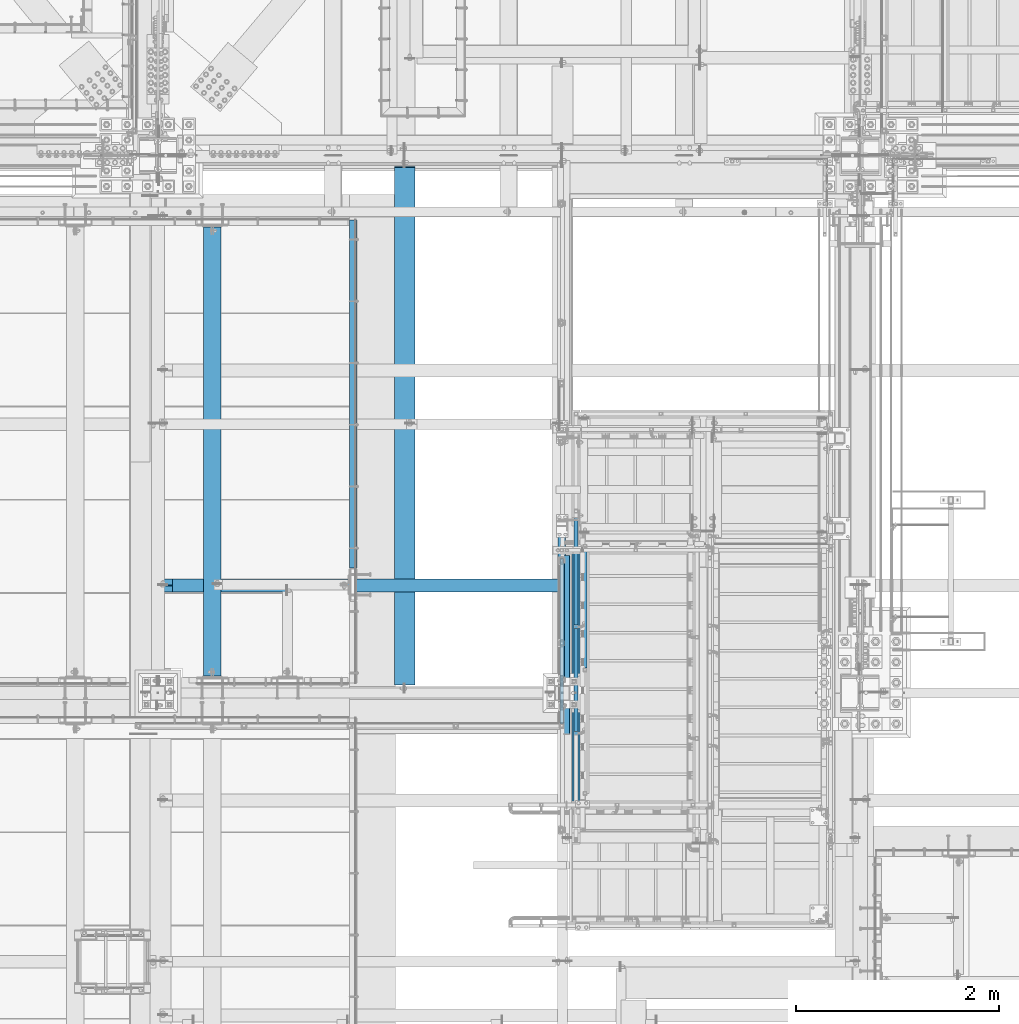
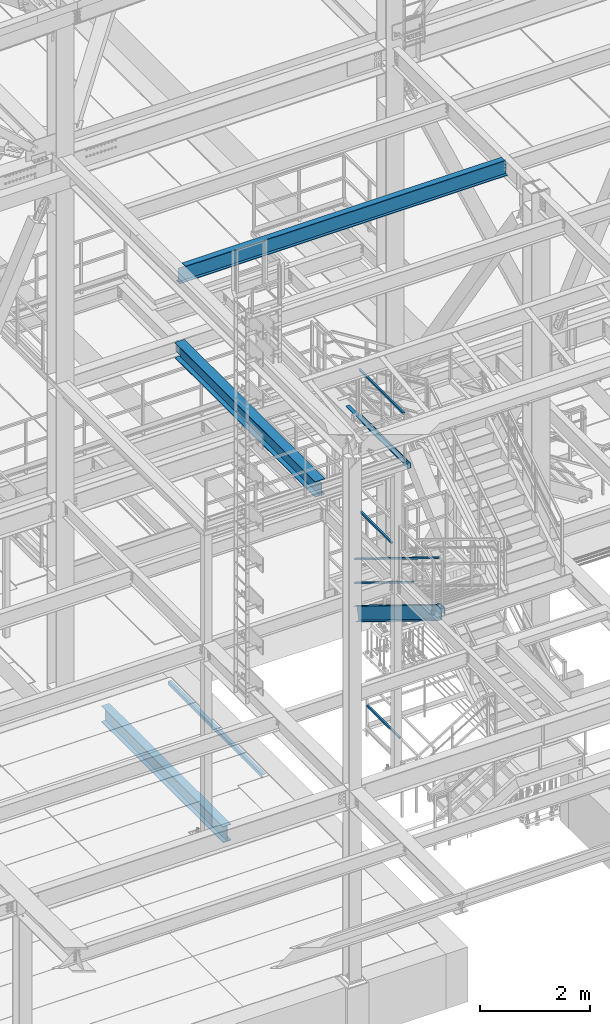
# One storey, part 1758 of 3843: 9 beams, 4 members, 11 elements without a shape of their own.
"""IFC2X3 building model written with IfcOpenShell, lengths in millimetres."""

from ifc_helpers import new_model, si_unit, frame, origin_with_axes, place, context, subcontext, project, spatial, faceted_brep, material, type_object, element, aggregate, save


model = new_model("IFC2X3")

# Units and contexts
model_context = context("Model", 3, precision=1e-05, world=origin_with_axes())
body_context = subcontext(model_context, "Body", "Model", "MODEL_VIEW")
ifc_project = project(units=[si_unit("LENGTHUNIT", "METRE", prefix="MILLI"), si_unit("AREAUNIT", "SQUARE_METRE"), si_unit("VOLUMEUNIT", "CUBIC_METRE"), si_unit("MASSUNIT", "GRAM", prefix="KILO"), si_unit("TIMEUNIT", "SECOND"), si_unit("PLANEANGLEUNIT", "RADIAN"), si_unit("SOLIDANGLEUNIT", "STERADIAN"), si_unit("THERMODYNAMICTEMPERATUREUNIT", "DEGREE_CELSIUS"), si_unit("LUMINOUSINTENSITYUNIT", "LUMEN")], contexts=[model_context])

# Site, building, storey
site_placement = place(None, origin_with_axes())
site = spatial("IfcSite", under=ifc_project, at=site_placement, CompositionType="ELEMENT")
building_placement = place(site_placement, origin_with_axes())
building = spatial("IfcBuilding", under=site, at=building_placement, Name="Undefined", CompositionType="ELEMENT")
storey_placement = place(building_placement, origin_with_axes())
storey = spatial("IfcBuildingStorey", under=building, at=storey_placement, Name="Undefined", CompositionType="ELEMENT", Elevation=0.0)

# Assembly, beam
assembly_1_placement = place(storey_placement, origin_with_axes())
assembly_1 = element("IfcElementAssembly", 1, at=assembly_1_placement, inside=storey, Name="RAIL", AssemblyPlace="NOTDEFINED", PredefinedType="RIGID_FRAME")
ifc_material_1 = material()
beam_type_1 = type_object("IfcBeamType", Name="HSS1-1/2X1-1/2X1/4", PredefinedType="NOTDEFINED")
beam_1_placement = place(assembly_1_placement, frame((52990.75, 21615.3999994262, 35483.7999969486), z_axis=(0.0, 0.0, 1.0), x_axis=(0.0, -1.0, 0.0)))
beam_1 = element("IfcBeam", 2, at=beam_1_placement, type_object=beam_type_1, material=ifc_material_1, Name="RAIL", ObjectType="HSS1-1/2X1-1/2X1/4", context=body_context, shape_type="Brep", body=[
    faceted_brep([(19.0499992350015, -19.0499992350015, -19.0499992350015), (19.0499992350015, -19.0499992350015, 19.0499992350015), (19.0499992350015, 19.0499992350015, 19.0499992350015), (19.0499992350015, 19.0499992350015, -19.0499992350015), (19.0499992350015, 12.6999993299978, 12.6999993299978), (19.0499992350015, -12.6999993299978, 12.6999993299978), (19.0499992350015, -12.6999993299978, -12.6999993299978), (19.0499992350015, 12.6999993299978, -12.6999993299978), (1155.70000095625, 19.0499992350015, -19.0499992350015), (1155.70000095625, -19.0499992350015, -19.0499992350015), (1155.70000095625, -19.0499992350015, 19.0499992350015), (1155.70000095625, 19.0499992350015, 19.0499992350015), (1155.70000095625, -12.6999993299978, 12.6999993299978), (1155.70000095625, 12.6999993299978, 12.6999993299978), (1155.70000095625, 12.6999993299978, -12.6999993299978), (1155.70000095625, -12.6999993299978, -12.6999993299978)], [[[0, 1, 2, 3], [4, 5, 6, 7]], [[8, 9, 0, 3]], [[9, 10, 1, 0]], [[10, 11, 2, 1]], [[11, 8, 3, 2]], [[10, 9, 8, 11], [12, 13, 14, 15]], [[13, 12, 5, 4]], [[14, 13, 4, 7]], [[15, 14, 7, 6]], [[12, 15, 6, 5]]]),
])
aggregate(assembly_1, [beam_1])

assembly_2_placement = place(storey_placement, origin_with_axes())
assembly_2 = element("IfcElementAssembly", 3, at=assembly_2_placement, inside=storey, Name="RAIL", AssemblyPlace="NOTDEFINED", PredefinedType="RIGID_FRAME")
beam_2_placement = place(assembly_2_placement, frame((52984.3999999344, 19964.399988558, 38633.3999983618), z_axis=(0.0, 0.0, -1.0), x_axis=(0.0, 1.0, 0.0)))
beam_2 = element("IfcBeam", 4, at=beam_2_placement, type_object=beam_type_1, material=ifc_material_1, Name="RAIL", ObjectType="HSS1-1/2X1-1/2X1/4", context=body_context, shape_type="Brep", body=[
    faceted_brep([(38.0999984699883, 12.6999993299978, -12.6999993300014), (38.0999984699883, -12.6999993299978, -12.6999993300014), (1663.70001078715, -12.6999993299978, -12.6999993299978), (1663.70001078715, 12.6999993299978, -12.6999993299978), (38.0999984699883, -12.6999993299978, 12.6999993300014), (1638.30001212715, -12.6999993299978, 12.6999993299978), (38.0999984699883, 12.6999993299978, 12.6999993300014), (1638.30001212715, 12.6999993299978, 12.6999993299978), (38.0999984699883, 19.0499992350015, -19.0499992350015), (38.0999984699883, 19.0499992350015, 19.0499992350015), (1631.95001222215, 19.0499992350015, 19.0499992350015), (1670.05001069215, 19.0499992350015, -19.0499992350015), (38.0999984699883, -19.0499992350015, 19.0499992350015), (1631.95001222215, -19.0499992350015, 19.0499992350015), (38.0999984699883, -19.0499992350015, -19.0499992350015), (1670.05001069215, -19.0499992350015, -19.0499992350015)], [[[0, 1, 2, 3]], [[1, 4, 5, 2]], [[4, 6, 7, 5]], [[6, 0, 3, 7]], [[8, 9, 10, 11]], [[9, 12, 13, 10]], [[12, 14, 15, 13]], [[14, 8, 11, 15]], [[13, 15, 11, 10], [5, 7, 3, 2]], [[14, 12, 9, 8], [6, 4, 1, 0]]]),
])
aggregate(assembly_2, [beam_2])

assembly_3_placement = place(storey_placement, origin_with_axes())
assembly_3 = element("IfcElementAssembly", 5, at=assembly_3_placement, inside=storey, Name="RAIL", AssemblyPlace="NOTDEFINED", PredefinedType="RIGID_FRAME")
beam_3_placement = place(assembly_3_placement, frame((53212.999999235, 20535.8999999874, 31013.4), z_axis=(0.0, 0.0, 1.0), x_axis=(0.0, 1.0, 0.0)))
beam_3 = element("IfcBeam", 6, at=beam_3_placement, type_object=beam_type_1, material=ifc_material_1, Name="RAIL", ObjectType="HSS1-1/2X1-1/2X1/4", context=body_context, shape_type="Brep", body=[
    faceted_brep([(1200.15000153688, -19.0499992350015, 19.0499992350015), (1200.15000153688, -19.0499992350015, -19.0499992350015), (1200.15000153688, 19.0499992350015, -19.0499992350015), (1200.15000153688, 19.0499992350015, 19.0499992350015), (1200.15000153688, -12.6999993299978, 12.6999993299978), (1200.15000153688, 12.6999993299978, 12.6999993299978), (1200.15000153688, 12.6999993299978, -12.6999993299978), (1200.15000153688, -12.6999993299978, -12.6999993299978), (19.0499992350015, 19.0499992350015, -19.0499992350015), (19.0499992350015, 19.0499992350015, 19.0499992350015), (19.0499992350015, -19.0499992350015, 19.0499992350015), (19.0499992350015, -19.0499992350015, -19.0499992350015), (19.0499992350015, 12.6999993299978, 12.6999993299978), (19.0499992350015, -12.6999993299978, 12.6999993299978), (19.0499992350015, -12.6999993299978, -12.6999993299978), (19.0499992350015, 12.6999993299978, -12.6999993299978)], [[[0, 1, 2, 3], [4, 5, 6, 7]], [[8, 9, 3, 2]], [[9, 10, 0, 3]], [[10, 11, 1, 0]], [[11, 8, 2, 1]], [[11, 10, 9, 8], [12, 13, 14, 15]], [[14, 13, 4, 7]], [[15, 14, 7, 6]], [[12, 15, 6, 5]], [[13, 12, 5, 4]]]),
])
aggregate(assembly_3, [beam_3])

# Assembly, members
assembly_4_placement = place(storey_placement, origin_with_axes())
assembly_4 = element("IfcElementAssembly", 7, at=assembly_4_placement, inside=storey, Name="RAIL", AssemblyPlace="NOTDEFINED", PredefinedType="RIGID_FRAME")
member_type_1 = type_object("IfcMemberType", Name="HSS1-1/2X1-1/2X1/4", PredefinedType="NOTDEFINED")
member_1_placement = place(assembly_4_placement, frame((53124.100000007, 20961.3499999856, 34252.8769202584), z_axis=(0.0, 0.5240974250506, 0.851658317082227), x_axis=(0.0, -0.851658317082228, 0.524097425050598)))
member_1 = element("IfcMember", 8, at=member_1_placement, type_object=member_type_1, material=ifc_material_1, Name="RAIL", ObjectType="HSS1-1/2X1-1/2X1/4", context=body_context, shape_type="Brep", body=[
    faceted_brep([(14.5527402998268, 12.6999993300014, -12.6999993299833), (14.5527402998268, -12.6999993300014, -12.6999993299833), (1203.79140701925, -12.6999993299978, -12.6999993324425), (1203.79140701925, 12.6999993299978, -12.6999993324425), (30.1835087105574, -12.6999993300014, 12.6999993299978), (1219.42217540003, -12.6999993299978, 12.6999993276258), (30.1835087105574, 12.6999993300014, 12.6999993299978), (1219.42217540003, 12.6999993299978, 12.6999993276258), (10.6450480494532, 19.0499992350015, -19.0499992349796), (34.091200960931, 19.0499992350015, 19.0499992349942), (1223.32986764292, 19.0499992350015, 19.0499992326368), (1199.88371477637, 19.0499992350015, -19.0499992374534), (34.091200960931, -19.0499992350015, 19.0499992349942), (1223.32986764292, -19.0499992350015, 19.0499992326368), (10.6450480494532, -19.0499992350015, -19.0499992349796), (1199.88371477637, -19.0499992350015, -19.0499992374534)], [[[0, 1, 2, 3]], [[1, 4, 5, 2]], [[4, 6, 7, 5]], [[6, 0, 3, 7]], [[8, 9, 10, 11]], [[9, 12, 13, 10]], [[12, 14, 15, 13]], [[14, 8, 11, 15]], [[13, 15, 11, 10], [5, 7, 3, 2]], [[14, 12, 9, 8], [6, 4, 1, 0]]]),
])
member_2_placement = place(assembly_4_placement, frame((53124.1000000089, 22034.5000000458, 33592.4769213096), z_axis=(0.0, 0.5240974250506, 0.851658317082227), x_axis=(0.0, -0.851658317082228, 0.524097425050598)))
member_2 = element("IfcMember", 9, at=member_2_placement, type_object=member_type_1, material=ifc_material_1, Name="RAIL", ObjectType="HSS1-1/2X1-1/2X1/4", context=body_context, shape_type="Brep", body=[
    faceted_brep([(-3.59463567009516, 12.6999993300014, -12.6999993299978), (-3.59463567009516, -12.6999993300014, -12.6999993299978), (1229.88755333165, -12.6999993299978, -12.6999993324789), (1229.88755333165, 12.6999993299978, -12.6999993324789), (3.59463559381402, -12.6999993300014, 12.6999993299833), (1245.51832171243, -12.6999993299978, 12.6999993275822), (3.59463559381402, 12.6999993300014, 12.6999993299833), (1245.51832171243, 12.6999993299978, 12.6999993275822), (-5.39195355401171, 19.0499992350015, -19.0499992349942), (5.39195347770146, 19.0499992350015, 19.0499992349796), (1249.42601395532, 19.0499992350015, 19.0499992325931), (1225.97986108877, 19.0499992350015, -19.0499992374971), (5.39195347770146, -19.0499992350015, 19.0499992349796), (1249.42601395532, -19.0499992350015, 19.0499992325931), (-5.39195355401171, -19.0499992350015, -19.0499992349942), (1225.97986108877, -19.0499992350015, -19.0499992374971)], [[[0, 1, 2, 3]], [[1, 4, 5, 2]], [[4, 6, 7, 5]], [[6, 0, 3, 7]], [[8, 9, 10, 11]], [[9, 12, 13, 10]], [[12, 14, 15, 13]], [[14, 8, 11, 15]], [[13, 15, 11, 10], [5, 7, 3, 2]], [[14, 12, 9, 8], [6, 4, 1, 0]]]),
])
member_3_placement = place(assembly_4_placement, frame((53124.0999999919, 18961.0999971336, 36017.1999969291), z_axis=(0.0, -0.5240974250506, -0.851658317082227), x_axis=(0.0, 0.851658317082228, -0.524097425050598)))
member_3 = element("IfcMember", 10, at=member_3_placement, type_object=member_type_1, material=ifc_material_1, Name="RAIL", ObjectType="HSS1-1/2X1-1/2X1/4", context=body_context, shape_type="Brep", body=[
    faceted_brep([(-3.59463567009516, 12.6999993300014, -12.6999993299978), (-3.59463567009516, -12.6999993300014, -12.6999993299978), (3605.1295924376, -12.6999993299978, -12.6999993372156), (3605.1295924376, 12.6999993299978, -12.6999993372156), (3.59463559381402, -12.6999993300014, 12.6999993299833), (3612.31886368554, -12.6999993299978, 12.6999993228674), (3.59463559381402, 12.6999993300014, 12.6999993299833), (3612.31886368554, 12.6999993299978, 12.6999993228674), (-5.39195355401171, 19.0499992350015, -19.0499992349942), (5.39195347770146, 19.0499992350015, 19.0499992349796), (3614.11618156546, 19.0499992350015, 19.0499992278783), (3603.33227455768, 19.0499992350015, -19.049999242241), (5.39195347770146, -19.0499992350015, 19.0499992349796), (3614.11618156546, -19.0499992350015, 19.0499992278783), (-5.39195355401171, -19.0499992350015, -19.0499992349942), (3603.33227455768, -19.0499992350015, -19.049999242241)], [[[0, 1, 2, 3]], [[1, 4, 5, 2]], [[4, 6, 7, 5]], [[6, 0, 3, 7]], [[8, 9, 10, 11]], [[9, 12, 13, 10]], [[12, 14, 15, 13]], [[14, 8, 11, 15]], [[13, 15, 11, 10], [5, 7, 3, 2]], [[14, 12, 9, 8], [6, 4, 1, 0]]]),
])
aggregate(assembly_4, [member_1, member_2, member_3])

# Assembly, beam
assembly_5_placement = place(storey_placement, origin_with_axes())
assembly_5 = element("IfcElementAssembly", 11, at=assembly_5_placement, inside=storey, Name="ref.", AssemblyPlace="NOTDEFINED", PredefinedType="RIGID_FRAME")
ifc_material_2 = material(Name="STEEL/Steel_Undefined")
beam_type_2 = type_object("IfcBeamType", PredefinedType="NOTDEFINED")
beam_4_placement = place(assembly_5_placement, frame((52984.3999999344, 22066.249987793, 37563.4249983618), z_axis=(1.0, 0.0, 0.0), x_axis=(0.0, -1.0, 0.0)))
beam_4 = element("IfcBeam", 12, at=beam_4_placement, type_object=beam_type_2, material=ifc_material_2, Name="ref.", context=body_context, shape_type="Brep", body=[
    faceted_brep([(0.0, 3.17500000000291, -38.0999999999985), (0.0, 3.17500000000291, 38.0999999999985), (2082.8, 3.17500000000291, 38.0999999999985), (2082.8, 3.17500000000291, -38.0999999999985), (0.0, -3.17500000000291, 38.0999999999985), (2082.8, -3.17500000000291, 38.0999999999985), (0.0, -3.17500000000291, -38.0999999999985), (2082.8, -3.17500000000291, -38.0999999999985)], [[[0, 1, 2, 3]], [[1, 4, 5, 2]], [[4, 6, 7, 5]], [[6, 0, 3, 7]], [[5, 7, 3, 2]], [[6, 4, 1, 0]]]),
])
aggregate(assembly_5, [beam_4])

# Assembly, member
assembly_6_placement = place(storey_placement, origin_with_axes())
assembly_6 = element("IfcElementAssembly", 13, at=assembly_6_placement, inside=storey, Name="STAIR", AssemblyPlace="NOTDEFINED", PredefinedType="RIGID_FRAME")
ifc_material_3 = material(Name="STEEL/A36")
member_type_2 = type_object("IfcMemberType", Name="C12X20.7", PredefinedType="NOTDEFINED")
member_4_placement = place(assembly_6_placement, frame((53124.1000000007, 21961.8168240169, 32954.6841938268), z_axis=(0.0, 0.5240974250506, 0.851658317082227), x_axis=(0.0, -0.851658317082228, 0.524097425050598)))
member_4 = element("IfcMember", 14, at=member_4_placement, type_object=member_type_2, material=ifc_material_3, Name="STAIR", ObjectType="C12X20.7", context=body_context, shape_type="Brep", body=[
    faceted_brep([(3477.78444080407, 30.1624999999985, -134.674927507411), (3470.78595927689, -38.0999999999985, -146.047460007438), (3466.87670389858, -38.0999999999985, -152.400000007459), (3466.87670389858, 38.0999999999985, -152.400000007459), (3558.68671779059, 38.0999999999985, -3.20872719031468), (3558.68671779059, 30.1624999999985, -3.20872719031468), (3645.21520280598, 30.1624999999985, -56.4570255759609), (3645.21520046979, 38.0999999999985, -56.4570241383044), (0.0, -38.0999999999985, 152.400000000001), (-1.79803789807193, -38.1000000000004, 146.047460000002), (3606.93103753184, -38.0999999999985, 146.04745999338), (3596.60816001522, -38.0999999999985, 152.399999993417), (0.0, 38.0999999999985, 152.400000000001), (3596.60816001522, 38.0999999999985, 152.399999993417), (-86.271260601221, -38.1000000000004, -152.400000000001), (-84.4732237670396, -38.1000000000004, -146.047460000002), (-81.2543172614387, 30.1625000000004, -134.6749275), (-5.01694440365827, 30.1625000000004, 134.6749275), (-86.271260601221, 38.1000000000004, -152.400000000001), (3625.41140287409, 30.1624999999985, 134.674927493295), (3725.08764644338, 30.1624999999985, 73.3357007797749), (3725.08764644338, 38.0999999999985, 73.3357007797749)], [[[0, 1, 2, 3, 4, 5]], [[6, 5, 4, 7]], [[8, 9, 10, 11]], [[12, 8, 11, 13]], [[14, 15, 16, 17, 9, 8, 12, 18]], [[9, 17, 19, 10]], [[13, 11, 10, 19, 20, 21]], [[21, 20, 6, 7]], [[3, 18, 12, 13, 21, 7, 4]], [[14, 18, 3, 2]], [[15, 14, 2, 1]], [[16, 15, 1, 0]], [[20, 19, 17, 16, 0, 5, 6]]]),
])
aggregate(assembly_6, [member_4])

# Assembly, beam
assembly_7_placement = place(storey_placement, origin_with_axes())
assembly_7 = element("IfcElementAssembly", 15, at=assembly_7_placement, inside=storey, Name="ANGLE", AssemblyPlace="NOTDEFINED", PredefinedType="RIGID_FRAME")
beam_type_3 = type_object("IfcBeamType", Name="L3X3X1/4", PredefinedType="NOTDEFINED")
beam_5_placement = place(assembly_7_placement, frame((50923.825, 24980.9, 30365.7000030518), z_axis=(0.0, 0.0, -1.0), x_axis=(0.0, -1.0, 0.0)))
beam_5 = element("IfcBeam", 16, at=beam_5_placement, type_object=beam_type_3, material=ifc_material_3, Name="ANGLE", ObjectType="L3X3X1/4", context=body_context, shape_type="Brep", body=[
    faceted_brep([(0.0, 38.0999999999985, -38.0999999999985), (0.0, 38.0999999999985, 38.0999999999985), (3438.525, 38.0999999999985, 38.0999999999985), (3438.525, 38.0999999999985, -38.0999999999985), (0.0, 31.75, 38.0999999999985), (3438.525, 31.75, 38.0999999999985), (0.0, 31.75, -31.75), (3438.525, 31.75, -31.75), (0.0, -38.0999999999985, -31.75), (3438.525, -38.0999999999985, -31.75), (0.0, -38.0999999999985, -38.0999999999985), (3438.525, -38.0999999999985, -38.0999999999985)], [[[0, 1, 2, 3]], [[1, 4, 5, 2]], [[4, 6, 7, 5]], [[6, 8, 9, 7]], [[8, 10, 11, 9]], [[10, 0, 3, 11]], [[5, 7, 9, 11, 3, 2]], [[10, 8, 6, 4, 1, 0]]]),
])
aggregate(assembly_7, [beam_5])

assembly_8_placement = place(storey_placement, origin_with_axes())
assembly_8 = element("IfcElementAssembly", 17, at=assembly_8_placement, inside=storey, Name="BEAM", AssemblyPlace="NOTDEFINED", PredefinedType="RIGID_FRAME")
beam_type_4 = type_object("IfcBeamType", PredefinedType="NOTDEFINED")
beam_6_placement = place(assembly_8_placement, frame((53003.45, 20783.9465, 37468.175), z_axis=(0.0, -1.0, 0.0), x_axis=(1.0, 0.0, 0.0)))
beam_6 = element("IfcBeam", 18, at=beam_6_placement, type_object=beam_type_4, material=ifc_material_3, Name="BENT_PLATE", context=body_context, shape_type="Brep", body=[
    faceted_brep([(0.0, -3.17500000000291, -883.0465), (0.0, -3.17500000000291, 883.0465), (0.0, 3.17500000000291, 883.0465), (0.0, 3.17500000000291, -883.0465), (57.1499999999942, 3.17500000000291, 883.0465), (57.1499999999942, 3.17500000000291, -883.0465), (63.5, -3.17500000000291, -883.0465), (63.5, -3.17500000000291, 883.0465), (57.1499999999942, 98.4249984741182, 883.0465), (57.1499999999942, 98.4249984741182, -883.0465), (63.5, 98.4249984741182, 883.0465), (63.5, 98.4249984741182, -883.0465)], [[[0, 1, 2, 3]], [[3, 2, 4, 5]], [[1, 0, 6, 7]], [[5, 4, 8, 9]], [[4, 2, 1, 7, 10, 8]], [[7, 6, 11, 10]], [[6, 0, 3, 5, 9, 11]], [[10, 11, 9, 8]]]),
])
aggregate(assembly_8, [beam_6])

assembly_9_placement = place(storey_placement, origin_with_axes())
assembly_9 = element("IfcElementAssembly", 19, at=assembly_9_placement, inside=storey, Name="BEAM", AssemblyPlace="NOTDEFINED", PredefinedType="RIGID_FRAME")
ifc_material_4 = material(Name="STEEL/A992")
beam_type_5 = type_object("IfcBeamType", Name="W14X26", PredefinedType="NOTDEFINED")
beam_7_placement = place(assembly_9_placement, frame((48996.6, 21369.02, 42292.5875), z_axis=(0.0, 0.0, 1.0), x_axis=(1.0, 0.0, 0.0)))
beam_7 = element("IfcBeam", 20, at=beam_7_placement, type_object=beam_type_5, material=ifc_material_4, Name="BEAM", ObjectType="W14X26", context=body_context, shape_type="Brep", body=[
    faceted_brep([(6851.64999694825, -63.5, 176.212500000001), (6851.64999694825, -63.5, 165.099999999999), (6851.64999694825, -3.17499999999927, 165.099999999999), (6851.64999694825, -3.17499999999927, 160.33749980927), (6851.64999694825, 3.17499999999927, 160.33749980927), (6851.64999694825, 3.17499999999927, 165.099999999999), (6851.64999694825, 63.5, 165.099999999999), (6851.64999694825, 63.5, 176.212500000001), (6852.61672687083, -3.17499999999927, 155.477420291223), (6852.61672687083, 3.17499999999927, 155.477420291223), (6855.36974077131, -3.17499999999927, 151.357243823069), (6855.36974077131, 3.17499999999927, 151.357243823069), (6859.48991723947, -3.17499999999927, 148.604229922596), (6859.48991723947, 3.17499999999927, 148.604229922596), (6864.34999675751, -3.17499999999927, 147.637500000004), (6864.34999675751, 3.17499999999927, 147.637500000004), (6918.325, -3.17499999999927, 147.637500000004), (6918.325, 3.17499999999927, 147.637500000004), (142.87500610351, -63.5, 176.212500000001), (142.87500610351, 63.5, 176.212500000001), (142.87500610351, 63.5, 165.099999999999), (142.87500610351, 3.17499999999927, 165.099999999999), (142.87500610351, 3.17499999999927, 149.224999809267), (142.87500610351, -3.17499999999927, 149.224999809267), (142.87500610351, -3.17499999999927, 165.099999999999), (142.87500610351, -63.5, 165.099999999999), (141.908276180919, 3.17499999999927, 144.36492029122), (141.908276180919, -3.17499999999927, 144.36492029122), (139.155262280445, 3.17499999999927, 140.244743823067), (139.155262280445, -3.17499999999927, 140.244743823067), (135.035085812291, 3.17499999999927, 137.491729922593), (135.035085812291, -3.17499999999927, 137.491729922593), (130.175006294245, 3.17499999999927, 136.525000000001), (130.175006294245, -3.17499999999927, 136.525000000001), (17.4624999999942, 3.17499999999927, 136.525000000001), (17.4624999999942, -3.17499999999927, 136.525000000001), (17.4624999999942, 3.17499999999927, 125.412499999999), (17.4624999999942, 3.17499999999927, -105.1875), (17.4624999999942, 3.17499999999927, -165.099999999999), (17.4624999999942, 63.5, -165.099999999999), (17.4624999999942, 63.5, -176.212500000001), (17.4624999999942, -63.5, -176.212500000001), (17.4624999999942, -63.5, -165.099999999999), (17.4624999999942, -3.17499999999927, -165.099999999999), (6918.325, 3.17499999999927, -165.099999999999), (6918.325, 63.5, -165.099999999999), (6918.325, 63.5, -176.212500000001), (6918.325, -63.5, -176.212500000001), (6918.325, -63.5, -165.099999999999), (6918.325, -3.17499999999927, -165.099999999999), (6918.325, 3.17499999999927, 125.412499999999), (6918.325, 3.17499999999927, -105.1875)], [[[0, 1, 2, 3, 4, 5, 6, 7]], [[8, 9, 4, 3]], [[10, 11, 9, 8]], [[12, 13, 11, 10]], [[14, 15, 13, 12]], [[16, 17, 15, 14]], [[18, 19, 20, 21, 22, 23, 24, 25]], [[23, 22, 26, 27]], [[27, 26, 28, 29]], [[29, 28, 30, 31]], [[31, 30, 32, 33]], [[33, 32, 34, 35]], [[36, 37, 38, 39, 40, 41, 42, 43, 35, 34]], [[39, 38, 44, 45]], [[40, 39, 45, 46]], [[41, 40, 46, 47]], [[42, 41, 47, 48]], [[43, 42, 48, 49]], [[12, 10, 8, 3, 2, 24, 23, 27, 29, 31, 33, 35, 43, 49, 16, 14]], [[25, 24, 2, 1]], [[18, 25, 1, 0]], [[19, 18, 0, 7]], [[20, 19, 7, 6]], [[21, 20, 6, 5]], [[50, 51, 44, 38, 37, 36, 34, 32, 30, 28, 26, 22, 21, 5, 4, 9, 11, 13, 15, 17]], [[49, 48, 47, 46, 45, 44, 51, 50, 17, 16]]]),
])
aggregate(assembly_9, [beam_7])

assembly_10_placement = place(storey_placement, origin_with_axes())
assembly_10 = element("IfcElementAssembly", 21, at=assembly_10_placement, inside=storey, Name="BEAM", AssemblyPlace="NOTDEFINED", PredefinedType="RIGID_FRAME")
beam_type_6 = type_object("IfcBeamType", Name="W14X43", PredefinedType="NOTDEFINED")
beam_8_placement = place(assembly_10_placement, frame((51435.0, 20307.3, 37291.9625), z_axis=(0.0, 0.0, 1.0), x_axis=(0.0, 1.0, 0.0)))
beam_8 = element("IfcBeam", 22, at=beam_8_placement, type_object=beam_type_6, material=ifc_material_4, Name="BEAM", ObjectType="W14X43", context=body_context, shape_type="Brep", body=[
    faceted_brep([(79.3750000000036, 101.599999999999, -173.037499999999), (79.3750000000036, 101.599999999999, -160.337500000001), (5190.93565607503, 101.599999999999, -160.337500000001), (5198.26784392498, 101.599999999999, -173.037499999999), (79.3750000000036, 3.96875, -160.337500000001), (5190.93565607503, 3.96875, -160.337500000001), (5157.79415325832, -3.96875, 150.284265447786), (5157.79415325832, 3.96875, 150.284265447786), (5185.56825000001, 3.96875, 159.940499999997), (5185.56825000001, -3.96875, 159.940499999997), (5153.48463595458, -3.96875, 147.238154167171), (5153.48463595458, 3.96875, 147.238154167171), (5151.458242379, -3.96875, 142.365325173465), (5151.458242379, 3.96875, 142.365325173465), (5152.33702998894, -3.96875, 137.161627866575), (5152.33702998894, 3.96875, 137.161627866575), (5155.85123066393, -3.96875, 133.224480810524), (5155.85123066393, 3.96875, 133.224480810524), (5160.92206347864, -3.96875, 131.762499999997), (5160.92206347864, 3.96875, 131.762499999997), (5291.93125000001, -3.96875, 131.762499999997), (5291.93125000001, 3.96875, 131.762499999997), (5291.93125000001, -3.96875, -131.762499999997), (5291.93125000001, 3.96875, -131.762499999997), (5159.48106347864, -3.96875, -131.762499999997), (5159.48106347864, 3.96875, -131.762499999997), (5154.41023066393, -3.96875, -133.224480810524), (5154.41023066393, 3.96875, -133.224480810524), (5150.89602998893, -3.96875, -137.161627866575), (5150.89602998893, 3.96875, -137.161627866575), (5150.017242379, -3.96875, -142.365325173465), (5150.017242379, 3.96875, -142.365325173465), (5152.04363595458, -3.96875, -147.238154167171), (5152.04363595458, 3.96875, -147.238154167171), (5156.35315325832, -3.96875, -150.284265447786), (5156.35315325832, 3.96875, -150.284265447786), (5184.12725000001, -3.96875, -159.940499999997), (5184.12725000001, 3.96875, -159.940499999997), (5190.70645303752, -3.96875, -159.940499999997), (5190.70645303752, 3.96875, -159.940499999997), (79.3750000000036, -101.599999999999, -160.33749980927), (79.3750000000036, -101.599999999999, -173.037499999999), (5198.26784392498, -101.599999999999, -173.037499999999), (5190.93565607264, -101.599999999999, -160.337499995847), (79.3750000000036, -3.96875, -160.337500000001), (5190.93565607503, -3.96875, -160.337500000001), (78.4082700774161, -3.96875, -155.477420291223), (78.4082700774161, 3.96875, -155.477420291223), (75.6552561769386, -3.96875, -151.357243823069), (75.6552561769386, 3.96875, -151.357243823069), (71.5350797087849, -3.96875, -148.604229922596), (71.5350797087849, 3.96875, -148.604229922596), (66.6750001907385, -3.96875, -147.637500000004), (66.6750001907385, 3.96875, -147.637500000004), (15.875, -3.96875, -147.637500000004), (15.875, 3.96875, -147.637500000004), (15.875, -3.96875, 147.637499999997), (15.875, 3.96875, 147.637499999997), (15.875, 3.96875, 134.9375), (15.875, 3.96875, -95.6624999999985), (66.6750001907385, -3.96875, 147.637499999997), (66.6750001907385, 3.96875, 147.637499999997), (71.5350797087849, -3.96875, 148.604229922588), (71.5350797087849, 3.96875, 148.604229922588), (75.6552561769386, -3.96875, 151.357243823062), (75.6552561769386, 3.96875, 151.357243823062), (78.4082700774161, -3.96875, 155.477420291216), (78.4082700774161, 3.96875, 155.477420291216), (79.3750000000036, -3.96875, 160.337500000001), (79.3750000000036, 3.96875, 160.337500000001), (79.3750000000036, -101.599999999999, 172.940233793772), (79.3750000000036, 101.599999999999, 173.037499999999), (79.3750000000036, 101.599999999999, 160.337500000001), (79.3750000000036, -101.599999999999, 160.337500000001), (5190.93567919894, 101.599999999999, 173.037499999999), (5198.26823691481, 101.599999999999, 160.337500000001), (5198.26823691481, 3.96875, 160.337500000001), (5198.49745154425, 3.96875, 159.940499948083), (5198.49745154425, -3.96875, 159.940499948083), (5198.26823691481, -3.96875, 160.337500000001), (5198.26823691481, -101.599999999999, 160.337500000001), (5190.93690112529, -101.599999999999, 173.035383621886)], [[[0, 1, 2, 3]], [[1, 4, 5, 2]], [[6, 7, 8, 9]], [[10, 11, 7, 6]], [[12, 13, 11, 10]], [[14, 15, 13, 12]], [[16, 17, 15, 14]], [[18, 19, 17, 16]], [[19, 18, 20, 21]], [[20, 22, 23, 21]], [[24, 25, 23, 22]], [[26, 27, 25, 24]], [[28, 29, 27, 26]], [[30, 31, 29, 28]], [[32, 33, 31, 30]], [[34, 35, 33, 32]], [[36, 37, 35, 34]], [[37, 36, 38, 39]], [[40, 41, 42, 43]], [[44, 40, 43, 45]], [[42, 3, 2, 5, 39, 38, 45, 43]], [[41, 0, 3, 42]], [[40, 44, 4, 1, 0, 41]], [[46, 47, 4, 44]], [[48, 49, 47, 46]], [[50, 51, 49, 48]], [[52, 53, 51, 50]], [[54, 55, 53, 52]], [[56, 57, 58, 59, 55, 54]], [[60, 61, 57, 56]], [[62, 63, 61, 60]], [[64, 65, 63, 62]], [[66, 67, 65, 64]], [[68, 69, 67, 66]], [[70, 71, 72, 69, 68, 73]], [[72, 71, 74, 75]], [[69, 72, 75, 76]], [[8, 7, 11, 13, 15, 17, 19, 21, 23, 25, 27, 29, 31, 33, 35, 37, 39, 5, 4, 47, 49, 51, 53, 55, 59, 58, 57, 61, 63, 65, 67, 69, 76, 77]], [[9, 8, 77, 78]], [[68, 66, 64, 62, 60, 56, 54, 52, 50, 48, 46, 44, 45, 38, 36, 34, 32, 30, 28, 26, 24, 22, 20, 18, 16, 14, 12, 10, 6, 9, 78, 79]], [[73, 68, 79, 80]], [[70, 73, 80, 81]], [[71, 70, 81, 74]], [[80, 79, 78, 77, 76, 75, 74, 81]]]),
])
aggregate(assembly_10, [beam_8])

assembly_11_placement = place(storey_placement, origin_with_axes())
assembly_11 = element("IfcElementAssembly", 23, at=assembly_11_placement, inside=storey, Name="BEAM", AssemblyPlace="NOTDEFINED", PredefinedType="RIGID_FRAME")
beam_type_7 = type_object("IfcBeamType", Name="W14X38", PredefinedType="NOTDEFINED")
beam_9_placement = place(assembly_11_placement, frame((49533.175, 20462.875, 30224.4125), z_axis=(0.0, 0.0, 1.0), x_axis=(0.0, 1.0, 0.0)))
beam_9 = element("IfcBeam", 24, at=beam_9_placement, type_object=beam_type_7, material=ifc_material_4, Name="BEAM", ObjectType="W14X38", context=body_context, shape_type="Brep", body=[
    faceted_brep([(12.7000030517447, 85.7249999999985, -179.387500000001), (12.7000030517447, 85.7249999999985, -166.6875), (4448.17499694826, 85.7249999999985, -166.6875), (4448.17499694826, 85.7249999999985, -179.387500000001), (12.7000030517447, 3.96875, -166.6875), (4448.17499694826, 3.96875, -166.6875), (12.7000030517447, 3.96875, 166.6875), (4448.17499694826, 3.96875, 166.6875), (12.7000030517447, 85.7249999999985, 166.6875), (4448.17499694826, 85.7249999999985, 166.6875), (12.7000030517447, 85.7249999999985, 179.387500000001), (4448.17499694826, 85.7249999999985, 179.387500000001), (12.7000030517447, -85.7249999999985, 179.387500000001), (4448.17499694826, -85.7249999999985, 179.387500000001), (12.7000030517447, -85.7249999999985, 166.6875), (4448.17499694826, -85.7249999999985, 166.6875), (12.7000030517447, -3.96875, 166.6875), (4448.17499694826, -3.96875, 166.6875), (12.7000030517447, -3.96875, -166.6875), (4448.17499694826, -3.96875, -166.6875), (12.7000030517447, -85.7249999999985, -166.6875), (4448.17499694826, -85.7249999999985, -166.6875), (12.7000030517447, -85.7249999999985, -179.387500000001), (4448.17499694826, -85.7249999999985, -179.387500000001)], [[[0, 1, 2, 3]], [[1, 4, 5, 2]], [[4, 6, 7, 5]], [[6, 8, 9, 7]], [[8, 10, 11, 9]], [[10, 12, 13, 11]], [[12, 14, 15, 13]], [[14, 16, 17, 15]], [[16, 18, 19, 17]], [[18, 20, 21, 19]], [[20, 22, 23, 21]], [[22, 0, 3, 23]], [[5, 7, 9, 11, 13, 15, 17, 19, 21, 23, 3, 2]], [[22, 20, 18, 16, 14, 12, 10, 8, 6, 4, 1, 0]]]),
])
aggregate(assembly_11, [beam_9])

save(model, "model.ifc")
